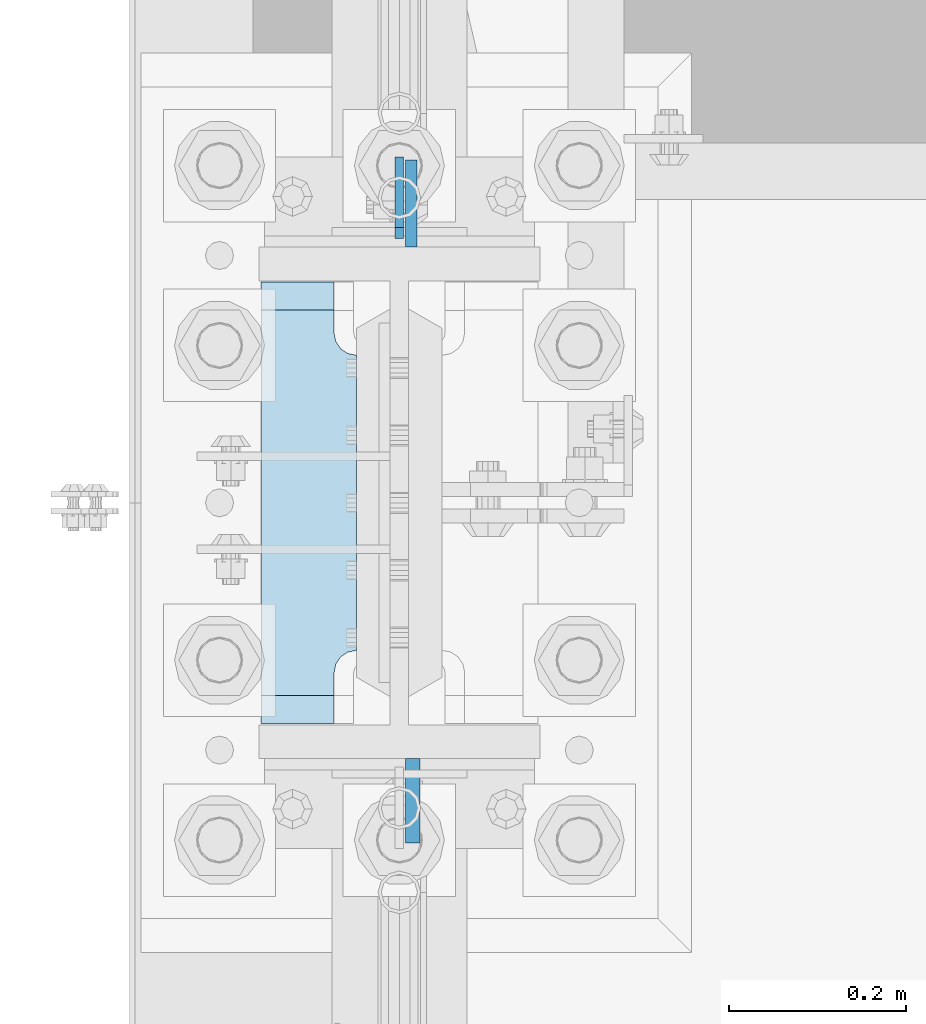
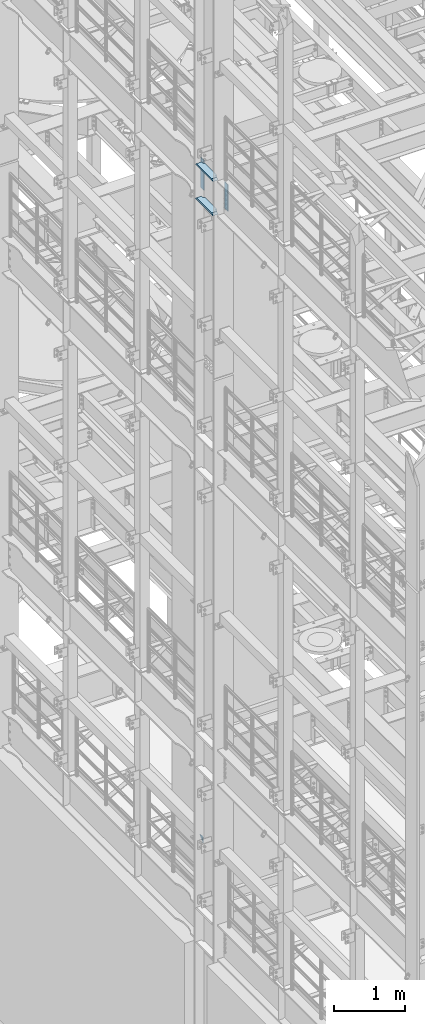
# One storey, part 1549 of 1876: 5 plates, 2 elements without a shape of their own.
"""IFC2X3 building model written with IfcOpenShell, lengths in millimetres."""

from ifc_helpers import new_model, si_unit, frame, origin_with_axes, place, context, subcontext, project, spatial, faceted_brep, material, type_object, element, aggregate, save


model = new_model("IFC2X3")

# Units and contexts
model_context = context("Model", 3, precision=1e-05, world=origin_with_axes())
body_context = subcontext(model_context, "Body", "Model", "MODEL_VIEW")
ifc_project = project(units=[si_unit("LENGTHUNIT", "METRE", prefix="MILLI"), si_unit("AREAUNIT", "SQUARE_METRE"), si_unit("VOLUMEUNIT", "CUBIC_METRE"), si_unit("MASSUNIT", "GRAM", prefix="KILO"), si_unit("TIMEUNIT", "SECOND"), si_unit("PLANEANGLEUNIT", "RADIAN"), si_unit("SOLIDANGLEUNIT", "STERADIAN"), si_unit("THERMODYNAMICTEMPERATUREUNIT", "DEGREE_CELSIUS"), si_unit("LUMINOUSINTENSITYUNIT", "LUMEN")], contexts=[model_context])

# Site, building, storey
site_placement = place(None, origin_with_axes())
site = spatial("IfcSite", under=ifc_project, at=site_placement, CompositionType="ELEMENT")
building_placement = place(site_placement, origin_with_axes())
building = spatial("IfcBuilding", under=site, at=building_placement, Name="Undefined", CompositionType="ELEMENT")
storey_placement = place(building_placement, origin_with_axes())
storey = spatial("IfcBuildingStorey", under=building, at=storey_placement, Name="Undefined", CompositionType="ELEMENT", Elevation=0.0)

# Assembly, plate
assembly_1_placement = place(storey_placement, origin_with_axes())
assembly_1 = element("IfcElementAssembly", 1, at=assembly_1_placement, inside=storey, Name="COLUMN", AssemblyPlace="NOTDEFINED", PredefinedType="RIGID_FRAME")
ifc_material_1 = material(Name="STEEL/A36")
plate_type_1 = type_object("IfcPlateType", PredefinedType="NOTDEFINED")
plate_1_placement = place(assembly_1_placement, frame((0.0, 1914.52500059683, 6235.7), z_axis=(0.0, -0.707106781186548, 0.707106781186548), x_axis=(0.0, -0.707106781186548, -0.707106781186548)))
plate_1 = element("IfcPlate", 2, at=plate_1_placement, type_object=plate_type_1, material=ifc_material_1, Name="PLATE", context=body_context, shape_type="Brep", body=[
    faceted_brep([(0.0, -4.76249999999982, 0.0), (56.1266013136901, -4.76249999997708, 56.1266013135391), (56.1266013136883, 4.76250000002256, 56.1266013135428), (0.0, 4.76249999999982, 0.0), (74.0871132860975, -4.7624999999698, 56.1266013135246), (74.0871132860993, 4.76250000002983, 56.1266013135282), (130.213714599717, -4.76249999994707, -1.30967237055302e-10), (130.213714599715, 4.76250000005257, -1.23691279441118e-10)], [[[0, 1, 2, 3]], [[1, 4, 5, 2]], [[4, 6, 7, 5]], [[6, 0, 3, 7]], [[5, 7, 3, 2]], [[6, 4, 1, 0]]]),
])
aggregate(assembly_1, [plate_1])

# Assembly, plates
assembly_2_placement = place(storey_placement, origin_with_axes())
assembly_2 = element("IfcElementAssembly", 3, at=assembly_2_placement, inside=storey, Name="COLUMN", AssemblyPlace="NOTDEFINED", PredefinedType="RIGID_FRAME")
ifc_material_2 = material(Name="STEEL/A572-50")
plate_type_2 = type_object("IfcPlateType", PredefinedType="NOTDEFINED")
plate_2_placement = place(assembly_2_placement, frame((13.493000125885, 1812.925, 17929.225), z_axis=(0.0, 1.0, 0.0), x_axis=(0.0, 0.0, -1.0)))
plate_2 = element("IfcPlate", 4, at=plate_2_placement, type_object=plate_type_2, material=ifc_material_2, Name="PLATE", context=body_context, shape_type="Brep", body=[
    faceted_brep([(0.0, -6.35000000000036, 0.0), (0.0, -6.34999999999991, 98.4250030517578), (0.0, 6.34999999999991, 98.4250030517578), (0.0, 6.35000000000036, 0.0), (514.349975585938, -6.35000000000036, 98.4250030517578), (514.349975585938, 6.35000000000036, 98.4250030517578), (514.349975585938, -6.35000000000036, 0.0), (514.349975585938, 6.35000000000036, 0.0)], [[[0, 1, 2, 3]], [[1, 4, 5, 2]], [[4, 6, 7, 5]], [[6, 0, 3, 7]], [[5, 7, 3, 2]], [[6, 4, 1, 0]]]),
])
plate_type_3 = type_object("IfcPlateType", PredefinedType="NOTDEFINED")
plate_3_placement = place(assembly_2_placement, frame((15.080500125885, 1235.075, 17919.7), z_axis=(0.0, -1.0, 0.0), x_axis=(0.0, 0.0, -1.0)))
plate_3 = element("IfcPlate", 5, at=plate_3_placement, type_object=plate_type_3, material=ifc_material_2, Name="PLATE", context=body_context, shape_type="Brep", body=[
    faceted_brep([(0.0, -7.9375, 0.0), (0.0, -7.9375, 95.25), (0.0, 7.9375, 95.25), (0.0, 7.9375, 0.0), (457.200012207031, -7.9375, 95.25), (457.200012207031, 7.9375, 95.25), (457.200012207031, -7.9375, 0.0), (457.200012207031, 7.9375, 0.0)], [[[0, 1, 2, 3]], [[1, 4, 5, 2]], [[4, 6, 7, 5]], [[6, 0, 3, 7]], [[5, 7, 3, 2]], [[6, 4, 1, 0]]]),
])
plate_type_4 = type_object("IfcPlateType", PredefinedType="NOTDEFINED")
plate_4_placement = place(assembly_2_placement, frame((-48.41875, 1274.7625, 17376.775012207), z_axis=(0.0, 1.0, 0.0), x_axis=(-1.0, 0.0, 0.0)))
plate_4 = element("IfcPlate", 6, at=plate_4_placement, type_object=plate_type_4, material=ifc_material_2, Name="PLATE", context=body_context, shape_type="Brep", body=[
    faceted_brep([(107.949996948242, -15.875, 498.475006103516), (107.949996948242, 15.875, 467.025007631571), (25.3999996185303, 15.875, 467.025007631571), (25.3999996185303, -15.875, 498.475006103516), (23.4665397733561, -15.875, 431.604843634198), (25.3999996185303, -15.875, 441.325002670288), (25.3999996185303, 15.875, 441.325002670288), (23.4665397733561, 15.875, 431.604843634198), (17.9605119724001, -15.875, 423.36449069789), (17.9605119724001, 15.875, 423.36449069789), (9.72015903609281, -15.875, 417.858462896934), (9.72015903609281, 15.875, 417.858462896934), (0.0, -15.875, 415.925003051758), (0.0, 15.875, 415.925003051758), (0.0, -15.875, 82.5500030517578), (0.0, 15.875, 82.5500030517578), (9.72015903609099, -15.875, 80.616543206582), (9.72015903609099, 15.875, 80.616543206582), (17.9605119723983, -15.875, 75.1105154056258), (17.9605119723983, 15.875, 75.1105154056258), (23.4665397733552, -15.875, 66.8701624693183), (23.4665397733552, 15.875, 66.8701624693183), (25.3999996185303, -15.875, 57.1500034332275), (25.3999996185303, 15.875, 57.1500034332275), (25.3999996185303, 15.875, 31.449998471945), (25.3999996185303, -15.875, 0.0), (107.949996948242, 15.875, 31.449998471945), (107.949996948242, -15.875, 0.0)], [[[0, 1, 2, 3]], [[4, 5, 6, 7]], [[8, 4, 7, 9]], [[10, 8, 9, 11]], [[12, 10, 11, 13]], [[14, 12, 13, 15]], [[16, 14, 15, 17]], [[18, 16, 17, 19]], [[20, 18, 19, 21]], [[22, 20, 21, 23]], [[22, 23, 24, 25]], [[26, 27, 25, 24]], [[5, 4, 8, 10, 12, 14, 16, 18, 20, 22, 25, 27, 0, 3]], [[6, 5, 3, 2]], [[26, 24, 23, 21, 19, 17, 15, 13, 11, 9, 7, 6, 2, 1]], [[27, 26, 1, 0]]]),
])
plate_5_placement = place(assembly_2_placement, frame((-48.41875, 1274.7625, 17967.325), z_axis=(0.0, 1.0, 0.0), x_axis=(-1.0, 0.0, 0.0)))
plate_5 = element("IfcPlate", 7, at=plate_5_placement, type_object=plate_type_4, material=ifc_material_2, Name="PLATE", context=body_context, shape_type="Brep", body=[
    faceted_brep([(107.949996948242, -15.875, 498.475006103516), (107.949996948242, 15.875, 467.025007631571), (25.3999996185303, 15.875, 467.025007631571), (25.3999996185303, -15.875, 498.475006103516), (23.4665397733561, -15.875, 431.604843634198), (25.3999996185303, -15.875, 441.325002670288), (25.3999996185303, 15.875, 441.325002670288), (23.4665397733561, 15.875, 431.604843634198), (17.9605119724001, -15.875, 423.36449069789), (17.9605119724001, 15.875, 423.36449069789), (9.72015903609281, -15.875, 417.858462896934), (9.72015903609281, 15.875, 417.858462896934), (0.0, -15.875, 415.925003051758), (0.0, 15.875, 415.925003051758), (0.0, -15.875, 82.5500030517578), (0.0, 15.875, 82.5500030517578), (9.72015903609099, -15.875, 80.616543206582), (9.72015903609099, 15.875, 80.616543206582), (17.9605119723983, -15.875, 75.1105154056258), (17.9605119723983, 15.875, 75.1105154056258), (23.4665397733552, -15.875, 66.8701624693183), (23.4665397733552, 15.875, 66.8701624693183), (25.3999996185303, -15.875, 57.1500034332275), (25.3999996185303, 15.875, 57.1500034332275), (25.3999996185303, 15.875, 31.449998471945), (25.3999996185303, -15.875, 0.0), (107.949996948242, 15.875, 31.449998471945), (107.949996948242, -15.875, 0.0)], [[[0, 1, 2, 3]], [[4, 5, 6, 7]], [[8, 4, 7, 9]], [[10, 8, 9, 11]], [[12, 10, 11, 13]], [[14, 12, 13, 15]], [[16, 14, 15, 17]], [[18, 16, 17, 19]], [[20, 18, 19, 21]], [[22, 20, 21, 23]], [[22, 23, 24, 25]], [[26, 27, 25, 24]], [[5, 4, 8, 10, 12, 14, 16, 18, 20, 22, 25, 27, 0, 3]], [[6, 5, 3, 2]], [[26, 24, 23, 21, 19, 17, 15, 13, 11, 9, 7, 6, 2, 1]], [[27, 26, 1, 0]]]),
])
aggregate(assembly_2, [plate_2, plate_3, plate_4, plate_5])

save(model, "model.ifc")
